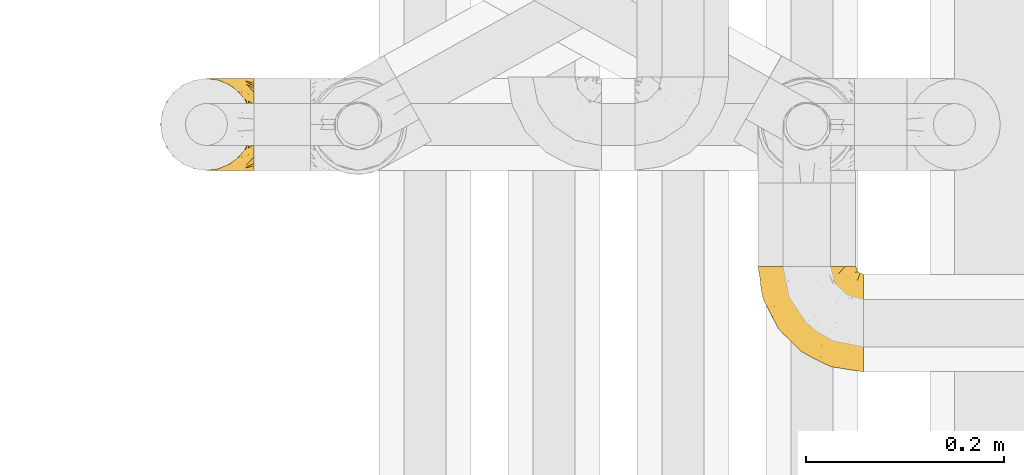
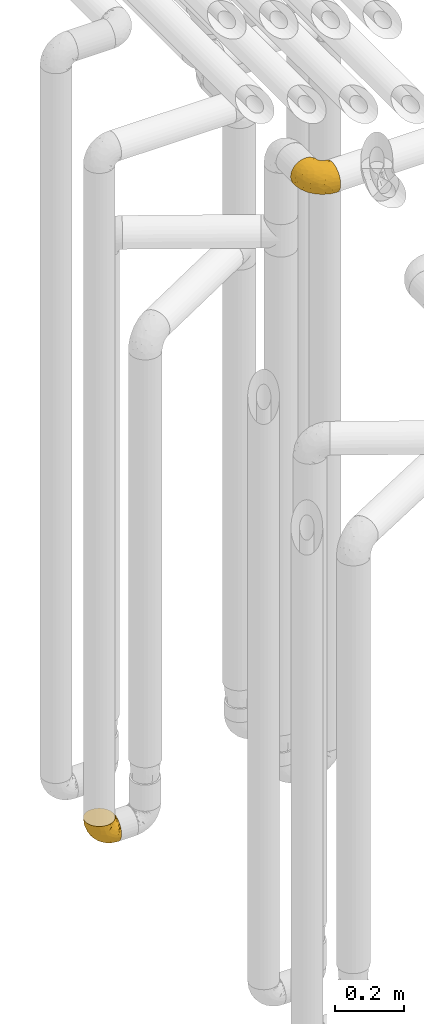
# One storey, part 170 of 827: 2 coverings.
"""IFC2X3 building model written with IfcOpenShell, lengths in millimetres."""

from ifc_helpers import new_model, entity, si_unit, converted_unit, derived_unit, direction, frame, origin, place, context, subcontext, project, spatial, faceted_brep, element, save


model = new_model("IFC2X3")

# Units and contexts
model_context = context("Model", 3, precision=0.01, world=origin(), true_north=direction((6.12303176911189e-17, 1.0)))
body_context = subcontext(model_context, "Body", "Model", "MODEL_VIEW")
ifc_project = project(units=[si_unit("LENGTHUNIT", "METRE", prefix="MILLI"), si_unit("AREAUNIT", "SQUARE_METRE"), si_unit("VOLUMEUNIT", "CUBIC_METRE"), converted_unit("PLANEANGLEUNIT", "DEGREE", entity("IfcRatioMeasure", 0.0174532925199433), si_unit("PLANEANGLEUNIT", "RADIAN"), dimensions=[0, 0, 0, 0, 0, 0, 0]), si_unit("MASSUNIT", "GRAM", prefix="KILO"), derived_unit("MASSDENSITYUNIT", [(si_unit("MASSUNIT", "GRAM", prefix="KILO"), 1), (si_unit("LENGTHUNIT", "METRE"), -3)]), derived_unit("MOMENTOFINERTIAUNIT", [(si_unit("LENGTHUNIT", "METRE"), 4)]), si_unit("TIMEUNIT", "SECOND"), si_unit("FREQUENCYUNIT", "HERTZ"), si_unit("THERMODYNAMICTEMPERATUREUNIT", "DEGREE_CELSIUS"), derived_unit("THERMALTRANSMITTANCEUNIT", [(si_unit("MASSUNIT", "GRAM", prefix="KILO"), 1), (si_unit("THERMODYNAMICTEMPERATUREUNIT", "KELVIN"), -1), (si_unit("TIMEUNIT", "SECOND"), -3)]), derived_unit("VOLUMETRICFLOWRATEUNIT", [(si_unit("LENGTHUNIT", "METRE"), 3), (si_unit("TIMEUNIT", "SECOND"), -1)]), derived_unit("MASSFLOWRATEUNIT", [(si_unit("MASSUNIT", "GRAM", prefix="KILO"), 1), (si_unit("TIMEUNIT", "SECOND"), -1)]), derived_unit("ROTATIONALFREQUENCYUNIT", [(si_unit("TIMEUNIT", "SECOND"), -1)]), si_unit("ELECTRICCURRENTUNIT", "AMPERE"), si_unit("ELECTRICVOLTAGEUNIT", "VOLT"), si_unit("POWERUNIT", "WATT"), si_unit("FORCEUNIT", "NEWTON", prefix="KILO"), si_unit("ILLUMINANCEUNIT", "LUX"), si_unit("LUMINOUSFLUXUNIT", "LUMEN"), si_unit("LUMINOUSINTENSITYUNIT", "CANDELA"), derived_unit("USERDEFINED", [(si_unit("MASSUNIT", "GRAM", prefix="KILO"), -1), (si_unit("LENGTHUNIT", "METRE"), -2), (si_unit("TIMEUNIT", "SECOND"), 3), (si_unit("LUMINOUSFLUXUNIT", "LUMEN"), 1)]), derived_unit("LINEARVELOCITYUNIT", [(si_unit("LENGTHUNIT", "METRE"), 1), (si_unit("TIMEUNIT", "SECOND"), -1)]), si_unit("PRESSUREUNIT", "PASCAL"), derived_unit("USERDEFINED", [(si_unit("LENGTHUNIT", "METRE"), -2), (si_unit("MASSUNIT", "GRAM", prefix="KILO"), 1), (si_unit("TIMEUNIT", "SECOND"), -2)]), derived_unit("LINEARFORCEUNIT", [(si_unit("MASSUNIT", "GRAM", prefix="KILO"), 1), (si_unit("LENGTHUNIT", "METRE"), 1), (si_unit("TIMEUNIT", "SECOND"), -2), (si_unit("LENGTHUNIT", "METRE"), -1)]), derived_unit("PLANARFORCEUNIT", [(si_unit("MASSUNIT", "GRAM", prefix="KILO"), 1), (si_unit("LENGTHUNIT", "METRE"), 1), (si_unit("TIMEUNIT", "SECOND"), -2), (si_unit("LENGTHUNIT", "METRE"), -2)])], contexts=[model_context])

# Site, building, storey
site_placement = place(None, origin())
site = spatial("IfcSite", under=ifc_project, at=site_placement, CompositionType="ELEMENT")
building_placement = place(site_placement, origin())
building = spatial("IfcBuilding", under=site, at=building_placement, CompositionType="ELEMENT")
storey_placement = place(building_placement, frame((0.0, 0.0, 28200.0)))
storey = spatial("IfcBuildingStorey", under=building, at=storey_placement, Name="08", CompositionType="ELEMENT", Elevation=28200.0)

# Coverings
covering_1_placement = place(storey_placement, frame((35674.29, 12505.34, 2549.25)))
element("IfcCovering", 1, at=covering_1_placement, inside=storey, Name=":ADSK_", ObjectType=":ADSK_", PredefinedType="INSULATION", context=body_context, shape_type="Brep", body=[
    faceted_brep([(107.75, 50.75, 99.9), (107.75, 39.8, 98.66), (107.75, 29.41, 95.02), (107.75, 20.09, 89.17), (107.75, 12.31, 81.38), (107.75, 6.46, 72.06), (107.75, 2.83, 61.68), (107.75, 1.6, 50.75), (107.75, 2.83, 39.8), (107.75, 6.47, 29.41), (107.75, 12.32, 20.09), (107.75, 20.11, 12.31), (107.75, 29.43, 6.46), (107.75, 39.81, 2.83), (107.75, 50.75, 1.6), (107.75, 56.45, 2.24), (107.75, 61.69, 2.83), (107.75, 66.88, 4.65), (107.75, 72.08, 6.47), (107.75, 81.4, 12.32), (107.75, 89.18, 20.11), (107.75, 95.03, 29.43), (107.75, 98.66, 39.81), (107.75, 99.9, 50.75), (107.75, 98.66, 61.69), (107.75, 95.02, 72.08), (107.75, 89.17, 81.4), (107.75, 81.38, 89.18), (107.75, 72.06, 95.03), (107.75, 66.87, 96.85), (107.75, 61.68, 98.66), (107.75, 56.45, 99.25), (107.75, 53.6, 99.57), (98.22, 107.75, 38.02), (93.31, 107.75, 26.17), (89.4, 107.75, 21.08), (85.5, 107.75, 15.99), (80.41, 107.75, 12.09), (75.32, 107.75, 8.18), (69.39, 107.75, 5.73), (63.47, 107.75, 3.27), (56.48, 107.75, 2.35), (53.61, 107.75, 1.97), (50.75, 107.75, 1.6), (38.02, 107.75, 3.27), (26.17, 107.75, 8.18), (15.99, 107.75, 15.99), (8.18, 107.75, 26.17), (3.27, 107.75, 38.02), (1.6, 107.75, 50.75), (3.27, 107.75, 63.47), (8.18, 107.75, 75.32), (15.99, 107.75, 85.5), (26.17, 107.75, 93.31), (38.02, 107.75, 98.22), (50.75, 107.75, 99.9), (56.48, 107.75, 99.14), (63.47, 107.75, 98.22), (69.39, 107.75, 95.77), (75.32, 107.75, 93.31), (80.41, 107.75, 89.4), (85.5, 107.75, 85.5), (89.4, 107.75, 80.41), (93.31, 107.75, 75.32), (98.22, 107.75, 63.47), (99.9, 107.75, 50.75), (27.53, 39.38, 59.31), (25.32, 49.75, 73.08), (16.29, 57.38, 63.72), (6.79, 74.94, 50.75), (4.51, 85.97, 58.64), (3.51, 95.66, 50.75), (17.47, 67.82, 76.74), (7.6, 83.09, 67.68), (12.27, 89.16, 78.92), (70.89, 37.01, 94.31), (87.17, 43.46, 98.76), (67.3, 51.79, 98.4), (31.65, 85.58, 94.57), (33.58, 62.84, 89.91), (47.23, 62.77, 96.32), (43.26, 88.17, 98.79), (55.08, 85.93, 99.9), (53.99, 91.42, 99.9), (52.9, 96.91, 99.9), (52.36, 99.62, 99.9), (51.82, 102.33, 99.9), (21.5, 82.57, 87.31), (89.94, 32.75, 95.61), (60.45, 13.79, 60.43), (83.0, 6.77, 65.24), (64.79, 16.46, 72.87), (85.93, 55.08, 99.9), (81.31, 58.17, 99.9), (76.69, 61.26, 99.9), (72.06, 64.35, 99.9), (67.44, 67.44, 99.9), (88.74, 24.18, 90.65), (45.98, 23.37, 63.14), (47.13, 49.76, 91.89), (89.4, 9.84, 75.25), (95.66, 3.51, 50.75), (28.5, 55.75, 82.18), (42.81, 42.34, 85.08), (38.28, 37.78, 76.93), (45.35, 21.87, 50.75), (33.61, 33.61, 50.75), (82.57, 17.1, 83.02), (105.04, 51.28, 99.9), (102.33, 51.82, 99.9), (96.91, 52.9, 99.9), (91.42, 53.99, 99.9), (65.92, 28.01, 87.13), (53.11, 28.99, 80.85), (54.37, 69.9, 99.17), (74.94, 6.79, 50.75), (64.35, 72.06, 99.9), (61.26, 76.69, 99.9), (58.17, 81.31, 99.9), (21.87, 45.35, 50.75), (34.79, 34.79, 67.61), (48.48, 25.72, 72.25), (60.15, 14.33, 50.75), (14.33, 60.15, 50.75), (99.07, 62.38, 98.69), (60.55, 100.57, 99.01), (64.18, 91.06, 98.79), (64.36, 97.66, 98.29), (103.17, 97.55, 68.51), (101.69, 93.65, 76.82), (87.75, 66.85, 98.54), (89.38, 61.93, 99.3), (88.34, 101.4, 83.57), (82.14, 100.07, 89.47), (94.51, 101.36, 75.76), (89.64, 95.94, 84.86), (98.41, 96.3, 75.89), (99.71, 101.98, 64.77), (89.37, 85.88, 90.83), (88.21, 78.88, 94.62), (95.2, 82.8, 90.37), (79.14, 102.58, 91.18), (101.22, 82.88, 88.65), (99.41, 88.57, 84.11), (84.72, 88.67, 91.75), (97.47, 69.08, 96.86), (102.19, 102.19, 50.75), (104.02, 100.06, 58.97), (82.66, 70.56, 98.37), (95.42, 91.07, 83.91), (78.67, 77.56, 97.52), (72.69, 96.59, 95.55), (66.46, 86.38, 98.76), (75.3, 91.79, 95.26), (72.74, 81.71, 98.04), (82.93, 94.11, 90.65), (99.27, 76.09, 93.51), (93.51, 76.91, 94.16), (67.35, 81.44, 99.1), (94.51, 101.37, 25.73), (82.94, 94.12, 10.84), (88.33, 101.41, 17.92), (89.64, 95.96, 16.64), (103.62, 96.22, 30.44), (87.74, 66.85, 2.95), (89.38, 61.94, 2.19), (81.31, 58.17, 1.6), (97.47, 69.1, 4.63), (99.41, 88.58, 17.39), (51.28, 105.04, 1.6), (52.9, 96.91, 1.6), (51.82, 102.33, 1.6), (101.21, 82.9, 12.86), (95.19, 82.82, 11.13), (64.36, 97.66, 3.2), (72.69, 96.59, 5.94), (79.14, 102.58, 10.31), (99.28, 76.13, 8.0), (93.51, 76.93, 7.34), (60.55, 100.57, 2.48), (66.46, 86.38, 2.73), (63.96, 90.86, 2.64), (96.91, 52.9, 1.6), (99.06, 62.39, 2.8), (99.7, 101.98, 36.71), (53.99, 91.42, 1.6), (55.08, 85.93, 1.6), (103.3, 99.49, 38.59), (102.33, 51.82, 1.6), (99.62, 52.36, 1.6), (76.69, 61.26, 1.6), (82.66, 70.56, 3.12), (95.42, 91.09, 17.59), (72.06, 64.35, 1.6), (78.68, 77.6, 3.98), (88.2, 78.89, 6.87), (72.75, 81.71, 3.45), (84.74, 88.69, 9.76), (91.42, 53.99, 1.6), (85.93, 55.08, 1.6), (98.41, 96.31, 25.62), (89.37, 85.9, 10.67), (67.35, 81.45, 2.39), (61.26, 76.69, 1.6), (75.3, 91.79, 6.23), (82.13, 100.07, 12.02), (58.17, 81.31, 1.6), (64.35, 72.06, 1.6), (67.44, 67.44, 1.6), (54.08, 69.6, 2.4), (4.51, 85.97, 42.85), (21.5, 82.57, 14.18), (33.43, 63.16, 11.56), (28.5, 55.81, 19.27), (17.47, 67.81, 24.75), (25.36, 49.73, 28.37), (90.18, 32.55, 5.95), (86.97, 43.23, 2.79), (43.26, 88.17, 2.71), (16.29, 57.38, 37.78), (7.6, 83.08, 33.81), (12.27, 89.16, 22.57), (31.65, 85.58, 6.92), (64.79, 16.46, 28.61), (83.0, 6.77, 36.24), (60.44, 13.8, 41.05), (38.35, 37.71, 24.55), (34.8, 34.8, 33.88), (71.54, 36.83, 7.11), (45.94, 23.39, 38.38), (27.53, 39.38, 42.18), (82.57, 17.12, 18.46), (88.74, 24.19, 10.84), (53.19, 28.89, 20.69), (48.49, 25.69, 29.27), (67.28, 51.77, 3.1), (52.32, 45.66, 9.18), (89.4, 9.85, 26.23), (65.75, 28.11, 14.34), (46.73, 62.27, 5.46), (42.82, 42.35, 16.39)], [[[0, 1, 2, 3, 4, 5, 6, 7, 8, 9, 10, 11, 12, 13, 14, 15, 16, 17, 18, 19, 20, 21, 22, 23, 24, 25, 26, 27, 28, 29, 30, 31, 32]], [[33, 34, 35, 36, 37, 38, 39, 40, 41, 42, 43, 44, 45, 46, 47, 48, 49, 50, 51, 52, 53, 54, 55, 56, 57, 58, 59, 60, 61, 62, 63, 64, 65]], [[66, 67, 68]], [[69, 70, 71]], [[68, 72, 73]], [[73, 72, 74]], [[75, 76, 77]], [[78, 79, 80]], [[51, 50, 73]], [[81, 82, 83, 84, 85, 86, 55]], [[52, 87, 53]], [[74, 52, 51]], [[2, 1, 88]], [[89, 90, 91]], [[77, 92, 93, 94, 95, 96]], [[55, 54, 81]], [[78, 53, 87]], [[5, 90, 6]], [[88, 76, 75]], [[97, 3, 2]], [[89, 91, 98]], [[99, 80, 79]], [[90, 5, 100]], [[74, 87, 52]], [[100, 5, 4]], [[90, 101, 6]], [[79, 102, 103]], [[102, 67, 104]], [[105, 98, 106]], [[107, 4, 3]], [[76, 0, 108, 109, 110, 111, 92]], [[107, 112, 113]], [[114, 77, 96]], [[89, 115, 90]], [[114, 96, 116, 117, 118, 82]], [[75, 97, 88]], [[119, 66, 68]], [[50, 71, 70]], [[100, 91, 90]], [[99, 77, 80]], [[102, 104, 103]], [[97, 107, 3]], [[80, 81, 78]], [[107, 97, 112]], [[68, 73, 70]], [[66, 98, 120]], [[78, 81, 54]], [[114, 81, 80]], [[53, 78, 54]], [[78, 87, 79]], [[102, 87, 72]], [[79, 103, 99]], [[4, 107, 100]], [[91, 100, 107]], [[88, 97, 2]], [[112, 97, 75]], [[99, 112, 75]], [[103, 104, 113]], [[91, 121, 98]], [[89, 105, 122, 115]], [[101, 90, 115]], [[101, 7, 6]], [[88, 1, 76]], [[0, 76, 1]], [[92, 77, 76]], [[73, 74, 51]], [[87, 74, 72]], [[81, 114, 82]], [[77, 114, 80]], [[87, 102, 79]], [[67, 102, 72]], [[68, 67, 72]], [[67, 120, 104]], [[120, 121, 104]], [[104, 121, 113]], [[121, 120, 98]], [[91, 107, 113]], [[91, 113, 121]], [[103, 113, 112]], [[106, 98, 66]], [[105, 89, 98]], [[106, 66, 119]], [[67, 66, 120]], [[68, 69, 123, 119]], [[50, 49, 71]], [[50, 70, 73]], [[112, 99, 103]], [[77, 99, 75]], [[69, 68, 70]], [[29, 124, 110]], [[84, 83, 125]], [[126, 82, 118]], [[59, 58, 127]], [[25, 128, 129]], [[130, 93, 131]], [[132, 62, 133]], [[134, 135, 136]], [[137, 65, 64]], [[64, 134, 137]], [[138, 139, 140]], [[111, 110, 124, 92]], [[134, 136, 137]], [[134, 64, 63]], [[133, 61, 141]], [[125, 58, 57]], [[142, 143, 140]], [[142, 26, 143]], [[127, 83, 82]], [[28, 124, 29]], [[108, 0, 32, 31, 30, 110, 109]], [[30, 29, 110]], [[135, 144, 138]], [[28, 145, 124]], [[57, 56, 55, 86, 85, 84]], [[146, 147, 23]], [[24, 23, 147]], [[25, 143, 26]], [[95, 94, 148]], [[24, 128, 25]], [[149, 138, 143]], [[124, 145, 131]], [[127, 58, 125]], [[150, 148, 139]], [[127, 126, 151]], [[151, 59, 127]], [[152, 151, 126]], [[153, 154, 155]], [[153, 133, 141]], [[145, 28, 27]], [[142, 156, 27]], [[157, 148, 130]], [[61, 133, 62]], [[134, 132, 135]], [[147, 128, 24]], [[65, 137, 146]], [[146, 137, 147]], [[128, 137, 136]], [[137, 128, 147]], [[128, 136, 129]], [[149, 129, 136]], [[25, 129, 143]], [[158, 152, 117]], [[152, 118, 117]], [[153, 151, 152]], [[158, 116, 154]], [[144, 150, 138]], [[153, 152, 158]], [[133, 153, 155]], [[133, 155, 132]], [[141, 61, 60]], [[135, 132, 155]], [[134, 63, 132]], [[144, 135, 155]], [[135, 138, 149]], [[155, 154, 144]], [[150, 154, 96]], [[154, 150, 144]], [[148, 94, 130]], [[82, 126, 127]], [[118, 152, 126]], [[150, 96, 95]], [[139, 148, 157]], [[150, 95, 148]], [[93, 92, 131]], [[130, 145, 156]], [[130, 94, 93]], [[84, 125, 57]], [[127, 125, 83]], [[140, 139, 157]], [[150, 139, 138]], [[140, 157, 142]], [[138, 140, 143]], [[156, 142, 157]], [[27, 26, 142]], [[130, 156, 157]], [[145, 27, 156]], [[132, 63, 62]], [[124, 131, 92]], [[130, 131, 145]], [[129, 149, 143]], [[135, 149, 136]], [[60, 151, 141]], [[59, 151, 60]], [[141, 151, 153]], [[116, 96, 154]], [[153, 158, 154]], [[158, 117, 116]], [[34, 33, 159]], [[160, 161, 162]], [[22, 21, 163]], [[164, 165, 166]], [[19, 18, 167]], [[168, 21, 20]], [[169, 43, 42, 41, 40, 170, 171]], [[172, 173, 168]], [[174, 38, 175]], [[176, 37, 36]], [[177, 164, 178]], [[40, 179, 170]], [[180, 181, 175]], [[17, 182, 183]], [[65, 146, 184]], [[185, 174, 186]], [[23, 22, 187]], [[174, 39, 38]], [[15, 14, 188, 189, 182, 16]], [[179, 40, 39]], [[190, 191, 164]], [[192, 163, 168]], [[33, 184, 159]], [[178, 173, 172]], [[193, 194, 191]], [[18, 183, 167]], [[173, 178, 195]], [[196, 197, 194]], [[198, 199, 183, 182]], [[182, 17, 16]], [[18, 17, 183]], [[200, 159, 184]], [[192, 168, 201]], [[187, 163, 200]], [[202, 203, 180]], [[185, 179, 174]], [[160, 204, 205]], [[206, 181, 180]], [[206, 180, 203]], [[199, 165, 183]], [[165, 164, 167]], [[172, 177, 178]], [[200, 192, 162]], [[205, 161, 160]], [[65, 184, 33]], [[163, 187, 22]], [[175, 204, 180]], [[174, 181, 186]], [[204, 196, 202]], [[197, 160, 162]], [[196, 207, 202]], [[205, 204, 176]], [[196, 204, 160]], [[176, 204, 175]], [[205, 35, 161]], [[34, 159, 161]], [[162, 161, 159]], [[200, 162, 159]], [[197, 162, 201]], [[194, 197, 201]], [[196, 160, 197]], [[191, 195, 178]], [[208, 196, 194]], [[186, 181, 206]], [[175, 181, 174]], [[191, 190, 193]], [[193, 208, 194]], [[195, 194, 201]], [[178, 164, 191]], [[168, 163, 21]], [[166, 165, 199]], [[166, 190, 164]], [[187, 200, 184]], [[184, 146, 187]], [[23, 187, 146]], [[174, 179, 39]], [[170, 179, 185]], [[194, 195, 191]], [[173, 201, 168]], [[201, 173, 195]], [[172, 168, 20]], [[20, 19, 172]], [[177, 172, 19]], [[19, 167, 177]], [[164, 177, 167]], [[35, 205, 36]], [[35, 34, 161]], [[183, 165, 167]], [[162, 192, 201]], [[163, 192, 200]], [[175, 38, 37]], [[205, 176, 36]], [[175, 37, 176]], [[204, 202, 180]], [[207, 196, 208]], [[207, 203, 202]], [[209, 186, 206, 203, 207, 208]], [[48, 210, 71]], [[211, 212, 213]], [[214, 213, 215]], [[216, 217, 13]], [[218, 43, 169, 171, 170, 185, 186]], [[219, 220, 214]], [[47, 46, 221]], [[210, 48, 220]], [[211, 222, 212]], [[222, 45, 44]], [[221, 220, 47]], [[47, 220, 48]], [[221, 211, 214]], [[223, 224, 225]], [[211, 46, 45]], [[226, 227, 215]], [[43, 218, 44]], [[217, 216, 228]], [[227, 229, 230]], [[14, 13, 217]], [[224, 9, 8]], [[10, 231, 11]], [[11, 232, 12]], [[233, 223, 234]], [[235, 208, 193, 190, 166, 199]], [[236, 235, 228]], [[222, 44, 218]], [[106, 230, 229]], [[224, 237, 9]], [[232, 238, 228]], [[9, 237, 10]], [[115, 224, 101]], [[239, 235, 236]], [[232, 11, 231]], [[223, 231, 237]], [[224, 8, 101]], [[223, 229, 234]], [[225, 115, 122, 105]], [[216, 12, 232]], [[209, 235, 239]], [[210, 219, 69]], [[219, 214, 215]], [[230, 119, 219]], [[209, 218, 186]], [[239, 212, 222]], [[239, 222, 218]], [[45, 222, 211]], [[236, 212, 239]], [[213, 212, 240]], [[223, 237, 224]], [[231, 10, 237]], [[238, 232, 231]], [[216, 232, 228]], [[233, 231, 223]], [[236, 238, 240]], [[115, 225, 224]], [[234, 229, 227]], [[8, 7, 101]], [[235, 209, 208]], [[218, 209, 239]], [[217, 228, 235]], [[13, 12, 216]], [[235, 199, 217]], [[217, 199, 198, 182, 189, 188, 14]], [[211, 221, 46]], [[220, 221, 214]], [[71, 210, 69]], [[71, 49, 48]], [[219, 210, 220]], [[226, 215, 213]], [[211, 213, 214]], [[226, 213, 240]], [[215, 227, 230]], [[233, 240, 238]], [[234, 227, 226]], [[233, 234, 226]], [[229, 223, 225]], [[240, 233, 226]], [[233, 238, 231]], [[225, 105, 229]], [[229, 105, 106]], [[106, 119, 230]], [[123, 69, 219, 119]], [[215, 230, 219]], [[238, 236, 228]], [[212, 236, 240]]]),
])
covering_2_placement = place(storey_placement, frame((35072.24, 12708.41, 352.2)))
element("IfcCovering", 2, at=covering_2_placement, inside=storey, Name=":ADSK_", ObjectType=":ADSK_", PredefinedType="INSULATION", context=body_context, shape_type="Brep", body=[
    faceted_brep([(95.8, 11.68, 18.98), (95.8, 19.0, 11.67), (95.8, 27.76, 6.17), (95.8, 37.52, 2.75), (95.8, 47.8, 1.6), (95.8, 58.08, 2.75), (95.8, 67.85, 6.17), (95.8, 76.61, 11.68), (95.8, 83.92, 19.0), (95.8, 89.42, 27.76), (95.8, 92.84, 37.52), (95.8, 94.0, 47.8), (95.8, 93.53, 51.94), (95.8, 93.18, 55.01), (95.8, 92.84, 58.08), (95.8, 91.13, 62.96), (95.8, 89.42, 67.85), (95.8, 86.66, 72.23), (95.8, 83.91, 76.61), (95.8, 80.25, 80.26), (95.8, 76.59, 83.92), (95.8, 67.83, 89.42), (95.8, 62.95, 91.13), (95.8, 58.07, 92.84), (95.8, 47.8, 94.0), (95.8, 37.51, 92.84), (95.8, 32.63, 91.13), (95.8, 27.74, 89.42), (95.8, 18.98, 83.91), (95.8, 15.33, 80.25), (95.8, 11.67, 76.59), (95.8, 8.92, 72.21), (95.8, 6.17, 67.83), (95.8, 4.46, 62.95), (95.8, 2.75, 58.07), (95.8, 2.41, 55.0), (95.8, 2.06, 51.94), (95.8, 1.6, 47.8), (95.8, 2.75, 37.51), (95.8, 6.17, 27.74), (94.0, 47.8, 95.8), (92.42, 59.75, 95.8), (87.81, 70.9, 95.8), (84.13, 75.68, 95.8), (80.46, 80.46, 95.8), (75.68, 84.13, 95.8), (70.9, 87.81, 95.8), (65.32, 90.11, 95.8), (59.75, 92.42, 95.8), (56.14, 92.9, 95.8), (54.06, 93.17, 95.8), (51.97, 93.45, 95.8), (47.8, 94.0, 95.8), (35.84, 92.42, 95.8), (24.7, 87.81, 95.8), (15.13, 80.46, 95.8), (7.78, 70.9, 95.8), (3.17, 59.75, 95.8), (1.6, 47.8, 95.8), (3.17, 35.84, 95.8), (7.78, 24.7, 95.8), (15.13, 15.13, 95.8), (24.7, 7.78, 95.8), (35.84, 3.17, 95.8), (47.8, 1.6, 95.8), (51.97, 2.14, 95.8), (56.14, 2.69, 95.8), (59.75, 3.17, 95.8), (65.32, 5.48, 95.8), (70.9, 7.78, 95.8), (75.68, 11.46, 95.8), (80.46, 15.13, 95.8), (84.13, 19.91, 95.8), (87.81, 24.7, 95.8), (92.42, 35.84, 95.8), (15.84, 23.61, 60.58), (6.99, 31.99, 74.11), (14.39, 35.87, 51.59), (6.21, 47.8, 66.69), (4.26, 40.43, 76.19), (3.39, 47.8, 84.43), (31.2, 31.83, 31.2), (26.47, 23.37, 42.88), (11.44, 21.41, 79.41), (47.66, 3.07, 60.7), (61.85, 1.6, 61.85), (59.25, 1.6, 65.75), (56.65, 1.6, 69.64), (54.05, 1.6, 73.53), (51.45, 1.6, 77.43), (19.8, 13.45, 74.59), (26.22, 15.25, 54.72), (31.58, 8.07, 64.18), (38.36, 16.0, 37.94), (51.54, 17.34, 25.89), (51.6, 10.58, 34.73), (55.97, 5.34, 42.89), (62.88, 2.39, 49.83), (41.35, 8.36, 48.58), (82.24, 10.04, 22.41), (40.88, 2.59, 78.69), (29.0, 6.28, 81.64), (74.06, 34.28, 6.22), (54.53, 38.73, 12.11), (57.98, 27.25, 14.81), (43.81, 29.88, 21.61), (38.22, 38.6, 22.41), (38.33, 23.44, 30.12), (74.76, 25.25, 10.01), (76.85, 17.23, 15.36), (84.43, 47.8, 3.39), (40.43, 47.8, 19.59), (30.01, 47.8, 30.01), (78.67, 2.53, 41.19), (92.06, 1.6, 48.54), (88.32, 1.6, 49.28), (85.6, 1.6, 49.82), (82.88, 1.6, 50.37), (80.15, 1.6, 50.91), (77.43, 1.6, 51.45), (76.36, 5.71, 31.61), (50.91, 1.6, 80.15), (50.37, 1.6, 82.88), (49.82, 1.6, 85.6), (49.28, 1.6, 88.32), (48.91, 1.6, 90.19), (48.54, 1.6, 92.06), (66.69, 47.8, 6.21), (73.53, 1.6, 54.05), (69.64, 1.6, 56.65), (65.75, 1.6, 59.25), (66.13, 11.89, 24.66), (19.59, 47.8, 40.43), (24.64, 39.69, 35.17), (53.56, 47.8, 12.9), (12.9, 47.8, 53.56), (82.81, 13.84, 85.34), (81.22, 9.16, 78.44), (86.57, 15.79, 84.37), (92.75, 25.75, 89.05), (89.68, 16.09, 82.76), (72.26, 7.51, 86.31), (64.73, 3.99, 83.73), (62.45, 2.66, 77.31), (60.63, 3.16, 87.78), (56.91, 2.35, 87.91), (58.14, 2.23, 81.29), (93.7, 38.35, 93.97), (83.4, 6.18, 70.76), (75.54, 2.7, 63.67), (79.46, 2.93, 62.62), (82.28, 16.01, 90.64), (76.25, 9.08, 84.08), (90.18, 11.68, 77.45), (87.92, 6.83, 70.34), (65.12, 4.65, 88.72), (71.71, 3.65, 71.28), (75.21, 3.61, 68.09), (78.6, 12.8, 91.07), (87.27, 2.43, 57.47), (86.94, 21.65, 91.35), (86.1, 3.7, 62.99), (94.52, 47.8, 94.52), (66.23, 3.37, 76.47), (84.69, 9.3, 76.28), (91.08, 7.03, 69.96), (71.77, 7.87, 89.86), (76.21, 7.26, 78.94), (68.59, 3.41, 73.51), (89.94, 23.81, 89.62), (76.25, 86.5, 84.09), (72.26, 88.08, 86.3), (78.6, 82.79, 91.06), (49.28, 94.0, 88.32), (48.54, 94.0, 92.06), (50.37, 94.0, 82.88), (49.82, 94.0, 85.6), (93.7, 57.24, 93.97), (89.95, 71.76, 89.63), (82.88, 94.0, 50.37), (85.6, 94.0, 49.82), (92.06, 94.0, 48.54), (88.32, 94.0, 49.28), (89.68, 79.49, 82.77), (87.92, 88.75, 70.36), (62.45, 92.93, 77.31), (66.24, 92.22, 76.47), (56.65, 94.0, 69.64), (59.25, 94.0, 65.75), (60.63, 92.43, 87.78), (56.91, 93.24, 87.91), (92.76, 69.82, 89.06), (82.28, 79.57, 90.65), (82.81, 81.74, 85.35), (54.05, 94.0, 73.53), (51.45, 94.0, 77.43), (58.14, 93.36, 81.29), (90.18, 83.9, 77.46), (84.7, 86.28, 76.29), (87.25, 93.16, 57.47), (75.58, 92.88, 63.71), (75.2, 91.98, 68.11), (83.39, 89.41, 70.77), (71.7, 91.93, 71.31), (81.22, 86.42, 78.46), (90.73, 88.82, 69.52), (79.47, 92.66, 62.64), (86.94, 73.93, 91.35), (65.75, 94.0, 59.25), (86.75, 79.5, 84.6), (86.08, 91.89, 62.98), (77.43, 94.0, 51.45), (73.53, 94.0, 54.05), (69.64, 94.0, 56.65), (64.73, 91.6, 83.73), (50.91, 94.0, 80.15), (65.12, 90.94, 88.72), (61.85, 94.0, 61.85), (68.62, 92.16, 73.56), (76.22, 88.32, 78.96), (74.03, 86.13, 91.36), (80.15, 94.0, 50.91), (49.81, 93.2, 62.87), (4.26, 55.16, 76.19), (19.95, 82.02, 73.57), (30.61, 84.29, 56.07), (25.71, 76.94, 49.77), (22.43, 68.33, 44.73), (15.85, 71.98, 60.58), (60.69, 92.52, 47.64), (40.49, 92.9, 78.32), (14.39, 59.72, 51.59), (6.99, 63.6, 74.11), (29.56, 88.89, 76.04), (11.45, 74.18, 79.41), (57.98, 68.35, 14.82), (74.06, 61.33, 6.22), (54.52, 56.86, 12.12), (43.47, 68.62, 23.51), (31.2, 63.76, 31.2), (33.27, 72.19, 34.96), (64.26, 88.69, 33.86), (74.29, 92.19, 38.94), (80.41, 89.75, 30.23), (24.64, 55.9, 35.17), (73.62, 77.99, 15.85), (78.98, 85.21, 22.59), (53.69, 74.99, 21.56), (42.86, 90.23, 55.94), (41.67, 59.86, 20.67), (79.66, 70.75, 9.19), (58.41, 81.72, 25.79), (47.11, 86.53, 41.16), (38.37, 79.6, 37.95)], [[[0, 1, 2, 3, 4, 5, 6, 7, 8, 9, 10, 11, 12, 13, 14, 15, 16, 17, 18, 19, 20, 21, 22, 23, 24, 25, 26, 27, 28, 29, 30, 31, 32, 33, 34, 35, 36, 37, 38, 39]], [[40, 41, 42, 43, 44, 45, 46, 47, 48, 49, 50, 51, 52, 53, 54, 55, 56, 57, 58, 59, 60, 61, 62, 63, 64, 65, 66, 67, 68, 69, 70, 71, 72, 73, 74]], [[75, 76, 77]], [[78, 79, 80]], [[77, 81, 82]], [[76, 75, 83]], [[84, 85, 86, 87, 88, 89]], [[90, 91, 92]], [[76, 60, 59]], [[93, 94, 95]], [[90, 62, 61]], [[83, 61, 60]], [[96, 97, 84]], [[98, 93, 95]], [[0, 39, 99]], [[100, 84, 89]], [[62, 101, 63]], [[2, 102, 3]], [[92, 84, 100]], [[103, 102, 104]], [[103, 105, 106]], [[93, 107, 94]], [[1, 108, 2]], [[92, 101, 90]], [[108, 1, 109]], [[102, 110, 3]], [[93, 82, 107]], [[102, 108, 104]], [[111, 106, 112]], [[109, 0, 99]], [[113, 37, 114, 115, 116, 117, 118, 119]], [[120, 38, 113]], [[100, 89, 121, 122, 123, 124, 125, 126, 64]], [[127, 102, 103]], [[97, 119, 128, 129, 130, 85]], [[99, 120, 131]], [[132, 133, 77]], [[59, 80, 79]], [[1, 0, 109]], [[98, 84, 92]], [[94, 109, 131]], [[120, 39, 38]], [[93, 91, 82]], [[104, 94, 105]], [[97, 113, 119]], [[95, 120, 96]], [[83, 90, 61]], [[91, 93, 98]], [[64, 63, 100]], [[100, 63, 101]], [[77, 76, 79]], [[133, 106, 81]], [[84, 97, 85]], [[113, 96, 120]], [[113, 97, 96]], [[37, 113, 38]], [[110, 102, 127]], [[110, 4, 3]], [[103, 111, 134, 127]], [[90, 75, 91]], [[82, 81, 107]], [[91, 75, 82]], [[77, 82, 75]], [[76, 83, 60]], [[90, 83, 75]], [[105, 107, 81]], [[94, 131, 95]], [[105, 94, 107]], [[109, 94, 104]], [[120, 95, 131]], [[98, 95, 96]], [[84, 98, 96]], [[98, 92, 91]], [[106, 105, 81]], [[103, 104, 105]], [[133, 132, 112]], [[103, 106, 111]], [[77, 78, 135, 132]], [[106, 133, 112]], [[77, 133, 81]], [[120, 99, 39]], [[109, 99, 131]], [[59, 58, 80]], [[59, 79, 76]], [[90, 101, 62]], [[100, 101, 92]], [[2, 108, 102]], [[109, 104, 108]], [[78, 77, 79]], [[136, 137, 138]], [[27, 139, 140]], [[141, 142, 143]], [[144, 145, 121]], [[146, 89, 88]], [[147, 139, 25]], [[148, 149, 150]], [[136, 151, 152]], [[147, 40, 74]], [[24, 147, 25]], [[153, 148, 154]], [[33, 116, 34]], [[73, 72, 151]], [[114, 37, 36, 35, 34, 116, 115]], [[146, 155, 144]], [[156, 85, 130]], [[157, 149, 148]], [[151, 158, 152]], [[117, 33, 159]], [[29, 153, 154]], [[160, 74, 73]], [[161, 128, 119]], [[66, 65, 64, 126, 125, 124, 123, 122, 67]], [[162, 147, 24]], [[27, 140, 28]], [[149, 129, 150]], [[139, 27, 26, 25]], [[68, 144, 69]], [[129, 128, 150]], [[163, 87, 86]], [[130, 129, 149]], [[122, 145, 67]], [[153, 164, 148]], [[161, 119, 159]], [[165, 30, 154]], [[150, 154, 148]], [[128, 161, 150]], [[30, 165, 31]], [[145, 144, 68]], [[89, 146, 144]], [[87, 163, 143]], [[166, 155, 142]], [[88, 87, 143]], [[161, 154, 150]], [[154, 30, 29]], [[29, 28, 153]], [[28, 140, 153]], [[164, 153, 140]], [[140, 137, 164]], [[157, 148, 164]], [[156, 130, 157]], [[164, 137, 157]], [[157, 137, 156]], [[167, 137, 136]], [[168, 85, 156]], [[152, 168, 167]], [[167, 168, 156]], [[163, 152, 141]], [[71, 158, 72]], [[152, 167, 136]], [[88, 142, 146]], [[144, 155, 69]], [[146, 142, 155]], [[70, 166, 71]], [[142, 141, 166]], [[70, 69, 155]], [[141, 158, 71]], [[160, 73, 151]], [[138, 137, 140]], [[160, 136, 169]], [[136, 160, 151]], [[74, 160, 169]], [[152, 158, 141]], [[151, 72, 158]], [[168, 152, 163]], [[137, 167, 156]], [[163, 86, 168]], [[85, 168, 86]], [[116, 33, 117]], [[130, 149, 157]], [[67, 145, 68]], [[121, 89, 144]], [[145, 122, 121]], [[40, 147, 162]], [[169, 147, 74]], [[159, 33, 32]], [[161, 159, 32]], [[159, 119, 118, 117]], [[139, 147, 169]], [[139, 169, 138]], [[161, 32, 31]], [[141, 143, 163]], [[88, 143, 142]], [[71, 166, 141]], [[155, 166, 70]], [[139, 138, 140]], [[169, 136, 138]], [[154, 161, 165]], [[161, 31, 165]], [[170, 171, 172]], [[173, 174, 52, 51, 50, 49, 48, 175, 176]], [[177, 178, 41]], [[179, 15, 180]], [[12, 11, 181, 182, 180, 14, 13]], [[183, 21, 20]], [[19, 18, 184]], [[185, 186, 187]], [[186, 188, 187]], [[43, 172, 44]], [[189, 190, 47]], [[23, 22, 21, 191]], [[170, 192, 193]], [[40, 162, 177]], [[194, 195, 196]], [[24, 23, 177]], [[197, 198, 183]], [[199, 15, 179]], [[47, 46, 189]], [[200, 201, 202]], [[201, 203, 204]], [[205, 206, 184]], [[207, 41, 178]], [[16, 15, 199]], [[14, 180, 15]], [[202, 201, 198]], [[208, 201, 200]], [[162, 24, 177]], [[48, 47, 190]], [[196, 195, 189]], [[197, 184, 202]], [[204, 193, 209]], [[210, 211, 212]], [[206, 212, 213]], [[205, 17, 210]], [[184, 206, 202]], [[210, 212, 206]], [[185, 194, 214]], [[189, 215, 190]], [[216, 45, 214]], [[186, 171, 170]], [[189, 216, 196]], [[19, 184, 197]], [[194, 185, 187]], [[19, 197, 20]], [[198, 197, 202]], [[183, 20, 197]], [[206, 200, 202]], [[204, 183, 198]], [[201, 208, 203]], [[203, 208, 217]], [[204, 198, 201]], [[217, 188, 218]], [[193, 219, 170]], [[171, 186, 185]], [[170, 218, 186]], [[170, 219, 218]], [[42, 207, 192]], [[171, 220, 172]], [[216, 189, 46]], [[214, 194, 196]], [[44, 220, 45]], [[214, 196, 216]], [[216, 46, 45]], [[214, 45, 220]], [[192, 43, 42]], [[204, 203, 219]], [[207, 193, 192]], [[209, 193, 178]], [[41, 207, 42]], [[193, 207, 178]], [[43, 192, 172]], [[170, 172, 192]], [[204, 219, 193]], [[219, 203, 218]], [[217, 218, 203]], [[188, 186, 218]], [[206, 213, 200]], [[208, 200, 213]], [[199, 210, 16]], [[215, 189, 195]], [[215, 175, 190]], [[175, 48, 190]], [[199, 179, 221, 211]], [[210, 199, 211]], [[23, 191, 177]], [[40, 177, 41]], [[183, 209, 191]], [[183, 191, 21]], [[191, 178, 177]], [[205, 18, 17]], [[17, 16, 210]], [[171, 185, 214]], [[172, 220, 44]], [[214, 220, 171]], [[191, 209, 178]], [[204, 209, 183]], [[206, 205, 210]], [[18, 205, 184]], [[222, 195, 194, 187, 188, 217]], [[57, 223, 80]], [[224, 225, 226]], [[226, 227, 228]], [[229, 217, 208, 213, 212, 211]], [[230, 52, 174, 173, 176, 175, 215, 195]], [[231, 232, 228]], [[231, 78, 223]], [[223, 57, 232]], [[224, 233, 225]], [[233, 54, 53]], [[234, 232, 56]], [[56, 55, 234]], [[234, 224, 228]], [[235, 236, 237]], [[224, 55, 54]], [[238, 239, 240]], [[52, 230, 53]], [[241, 242, 243]], [[227, 244, 231]], [[11, 10, 242]], [[236, 6, 5]], [[7, 245, 8]], [[8, 246, 9]], [[238, 247, 235]], [[222, 229, 248]], [[242, 211, 221, 179, 180, 182, 181, 11]], [[233, 53, 230]], [[111, 112, 249]], [[250, 6, 236]], [[246, 251, 241]], [[6, 250, 7]], [[127, 236, 110]], [[248, 229, 252]], [[246, 8, 245]], [[235, 245, 250]], [[236, 5, 110]], [[235, 249, 238]], [[237, 236, 127]], [[243, 9, 246]], [[252, 229, 241]], [[56, 232, 57]], [[222, 230, 195]], [[225, 248, 252]], [[248, 233, 230]], [[54, 233, 224]], [[231, 228, 227]], [[244, 132, 231]], [[248, 225, 233]], [[226, 225, 253]], [[235, 250, 236]], [[245, 7, 250]], [[251, 246, 245]], [[243, 246, 241]], [[247, 245, 235]], [[252, 251, 253]], [[229, 222, 217]], [[230, 222, 248]], [[5, 4, 110]], [[237, 127, 134, 111]], [[238, 249, 239]], [[224, 234, 55]], [[232, 234, 228]], [[242, 241, 229]], [[10, 9, 243]], [[211, 242, 229]], [[10, 243, 242]], [[80, 223, 78]], [[80, 58, 57]], [[231, 223, 232]], [[227, 240, 239]], [[224, 226, 228]], [[240, 226, 253]], [[227, 239, 244]], [[226, 240, 227]], [[251, 247, 253]], [[240, 253, 247]], [[249, 235, 237]], [[237, 111, 249]], [[112, 132, 244]], [[112, 244, 249]], [[78, 231, 132, 135]], [[249, 244, 239]], [[247, 238, 240]], [[245, 247, 251]], [[251, 252, 241]], [[225, 252, 253]]]),
])

save(model, "model.ifc")
